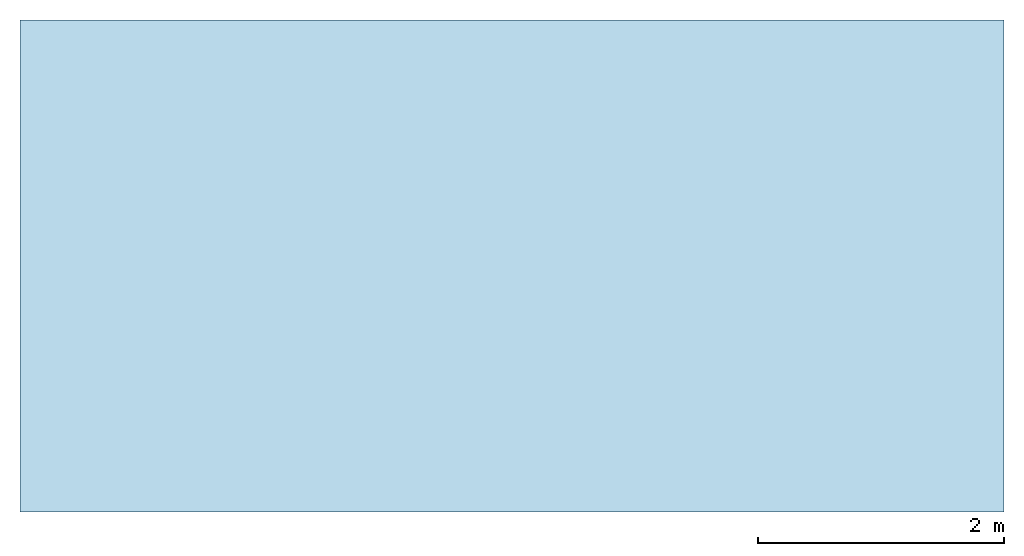
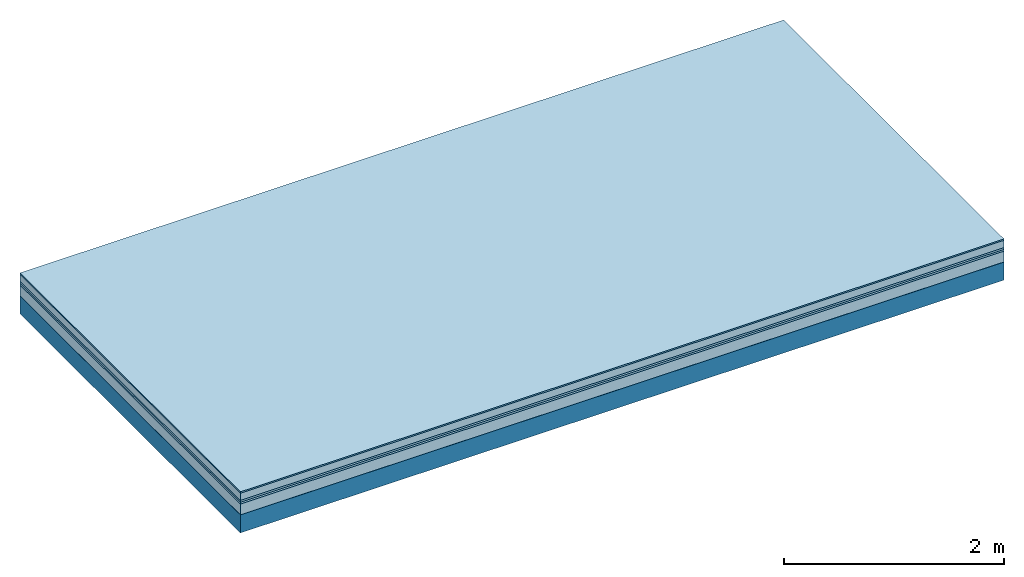
# One storey: 6 plates, 1 member, 1 element without a shape of its own.
"""IFC4 building model written with IfcOpenShell, lengths in metres."""

import ifcopenshell
import ifcopenshell.guid

model = None  # the IFC model being written
_history = None  # IfcOwnerHistory: only IFC2X3 demands one
_inside = {}  # id of a spatial element -> (the spatial element, [elements in it])
_under = {}  # id of a project, library or spatial element -> (it, [spatial elements below it])
_declared = {}  # id of a project -> (the project, [libraries it declares])
_typed = {}  # id of a type object -> (the type object, [elements of that type])
_made_of = {}  # id of a material, layer set ... -> (it, [elements and type objects made of it])


def new_model(schema):
    """Start an empty IFC model of exactly this schema.

    Asked for "IFC4X3", IfcOpenShell would pick the latest addendum, in which some entities
    have other attributes; the version numbers below select the first issue.
    IFC2X3 requires an IfcOwnerHistory on every rooted entity: one is made here for all.
    """
    global model, _history
    if schema == "IFC4X3":
        model = ifcopenshell.file(schema_version=(4, 3, 0, 0))
    else:
        model = ifcopenshell.file(schema=schema)
    _inside.clear()
    _under.clear()
    _declared.clear()
    _typed.clear()
    _made_of.clear()
    _history = None
    if model.schema == "IFC2X3":
        org = make("IfcOrganization", Name="unknown")
        user = make(
            "IfcPersonAndOrganization",
            ThePerson=make("IfcPerson", FamilyName="unknown"),
            TheOrganization=org,
        )
        app = make(
            "IfcApplication",
            ApplicationDeveloper=org,
            Version="unknown",
            ApplicationFullName="unknown",
            ApplicationIdentifier="unknown",
        )
        _history = make(
            "IfcOwnerHistory",
            OwningUser=user,
            OwningApplication=app,
            ChangeAction="ADDED",
            CreationDate=0,
        )
    return model


def make(cls, **values):
    """One entity of the class cls with the attributes given. An attribute that is None is left unset."""
    return model.create_entity(
        cls, **{name: value for name, value in values.items() if value is not None}
    )


def rooted(cls, **values):
    """An entity with a GlobalId (a new one), such as an element, a storey or a relation."""
    return make(cls, GlobalId=ifcopenshell.guid.new(), OwnerHistory=_history, **values)


def si_unit(unit_type, name, prefix=None):
    """IfcSIUnit, for example si_unit("LENGTHUNIT", "METRE", prefix="MILLI")."""
    return make("IfcSIUnit", UnitType=unit_type, Prefix=prefix, Name=name)


def derived_unit(unit_type, elements):
    """IfcDerivedUnit: a product of units, each with its exponent."""
    return make(
        "IfcDerivedUnit",
        Elements=[
            make("IfcDerivedUnitElement", Unit=unit, Exponent=power)
            for unit, power in elements
        ],
        UnitType=unit_type,
    )


def assignment(units):
    """IfcUnitAssignment: the units of a project."""
    return None if units is None else make("IfcUnitAssignment", Units=units)


def point(xyz):
    """IfcCartesianPoint."""
    return None if xyz is None else make("IfcCartesianPoint", Coordinates=xyz)


def direction(xyz):
    """IfcDirection."""
    return None if xyz is None else make("IfcDirection", DirectionRatios=xyz)


def frame(location, z_axis=None, x_axis=None):
    """IfcAxis2Placement3D, a coordinate frame: its origin and axes. An axis left out is left unset."""
    return make(
        "IfcAxis2Placement3D",
        Location=point(location),
        Axis=direction(z_axis),
        RefDirection=direction(x_axis),
    )


def frame_2d(location, x_axis=None):
    """IfcAxis2Placement2D, a coordinate frame in the plane: its origin and x axis."""
    return make(
        "IfcAxis2Placement2D", Location=point(location), RefDirection=direction(x_axis)
    )


def origin():
    """The frame at (0, 0, 0) with its axes left unset."""
    return frame((0.0, 0.0, 0.0))


def origin_with_axes():
    """The frame at (0, 0, 0) with the z axis (0, 0, 1) and the x axis (1, 0, 0) written out."""
    return frame((0.0, 0.0, 0.0), z_axis=(0.0, 0.0, 1.0), x_axis=(1.0, 0.0, 0.0))


def place(relative_to, where):
    """IfcLocalPlacement: puts the frame where relative to a parent placement (None: the world)."""
    return make(
        "IfcLocalPlacement", PlacementRelTo=relative_to, RelativePlacement=where
    )


def context(
    kind, dimensions, precision=None, world=None, true_north=None, identifier=None
):
    """IfcGeometricRepresentationContext, for example the 3D "Model" context."""
    return make(
        "IfcGeometricRepresentationContext",
        ContextIdentifier=identifier,
        ContextType=kind,
        CoordinateSpaceDimension=dimensions,
        Precision=precision,
        WorldCoordinateSystem=world,
        TrueNorth=true_north,
    )


def project(units=None, contexts=None):
    """IfcProject with its units and contexts."""
    return rooted(
        "IfcProject",
        Name="project",
        RepresentationContexts=contexts,
        UnitsInContext=assignment(units),
    )


def spatial(cls, under=None, at=None, **own):
    """A site, building, storey or space (cls), placed at a placement, below another one or the project."""
    s = rooted(cls, ObjectPlacement=at, **own)
    if under is not None:
        _under.setdefault(under.id(), (under, []))[1].append(s)
    return s


def profile(cls, at=None, kind="AREA", **sizes):
    """A parametric profile (cls). Its sizes go by their IFC names, for example OverallWidth=200.0."""
    return make(cls, ProfileType=kind, Position=at, **sizes)


def rectangle(**sizes):
    """IfcRectangleProfileDef."""
    return profile("IfcRectangleProfileDef", **sizes)


def extrude(swept, where, along, depth):
    """IfcExtrudedAreaSolid: the profile swept, set in the frame where, extruded along a direction by depth."""
    return make(
        "IfcExtrudedAreaSolid",
        SweptArea=swept,
        Position=where,
        ExtrudedDirection=direction(along),
        Depth=depth,
    )


def shape(context_of_items, identifier, shape_type, items):
    """IfcShapeRepresentation: the items that make up one representation, for example the "Body"."""
    return make(
        "IfcShapeRepresentation",
        ContextOfItems=context_of_items,
        RepresentationIdentifier=identifier,
        RepresentationType=shape_type,
        Items=items,
    )


def material(Name=None, Category=None):
    """IfcMaterial."""
    return make("IfcMaterial", Name=Name, Category=Category)


def layer(
    of_material, thickness, ventilated=None, Name=None, Category=None, Priority=None
):
    """IfcMaterialLayer: one layer of a wall or slab, of a material (None: an air gap)."""
    return make(
        "IfcMaterialLayer",
        Material=of_material,
        LayerThickness=thickness,
        IsVentilated=ventilated,
        Name=Name,
        Category=Category,
        Priority=Priority,
    )


def layer_set(layers, Name=None):
    """IfcMaterialLayerSet."""
    return make("IfcMaterialLayerSet", MaterialLayers=layers, LayerSetName=Name)


def made_of(thing, what):
    """Note that an element or type object is made of a material, layer set ...; save() writes the relation."""
    if what is not None:
        _made_of.setdefault(what.id(), (what, []))[1].append(thing)
    return thing


def type_object(cls, material=None, **own):
    """A type object (cls), such as IfcWallType, which elements share."""
    return made_of(rooted(cls, **own), material)


def element(
    cls,
    number,
    at=None,
    inside=None,
    cuts=None,
    type_object=None,
    material=None,
    context=None,
    identifier="Body",
    shape_type=None,
    held_by="IfcProductDefinitionShape",
    body=None,
    shapes=None,
    **own,
):
    """One element of the class cls, such as IfcWall. Its Tag is "e" and its number.

    at: its placement. inside: the storey or other place that contains it. cuts: it is an
    opening in that element (IfcRelVoidsElement). A single representation is given by context,
    identifier, shape_type and body (its items); several are given by shapes. held_by: the class
    of the entity that holds the representations. save() writes the other relations.
    """
    e = rooted(cls, Tag="e%d" % number, ObjectPlacement=at, **own)
    if body is not None:
        shapes = [shape(context, identifier, shape_type, body)]
    if shapes is not None:
        e.Representation = make(held_by, Representations=shapes)
    if inside is not None:
        _inside.setdefault(inside.id(), (inside, []))[1].append(e)
    if cuts is not None:
        rooted(
            "IfcRelVoidsElement", RelatingBuildingElement=cuts, RelatedOpeningElement=e
        )
    if type_object is not None:
        _typed.setdefault(type_object.id(), (type_object, []))[1].append(e)
    return made_of(e, material)


def aggregate(whole, parts):
    """IfcRelAggregates: a whole, such as a stair, and the parts it consists of."""
    return rooted("IfcRelAggregates", RelatingObject=whole, RelatedObjects=parts)


def save(model, path):
    """Write the relations noted so far, then the file.

    IfcRelAggregates (storeys below a building ...), IfcRelContainedInSpatialStructure (elements
    in a storey), IfcRelDefinesByType, IfcRelAssociatesMaterial and IfcRelDeclares: one each for
    every whole, place, type object, material and project.
    """
    for whole, parts in _under.values():
        aggregate(whole, parts)
    for where, things in _inside.values():
        rooted(
            "IfcRelContainedInSpatialStructure",
            RelatedElements=things,
            RelatingStructure=where,
        )
    for kind, things in _typed.values():
        rooted("IfcRelDefinesByType", RelatedObjects=things, RelatingType=kind)
    for what, things in _made_of.values():
        rooted("IfcRelAssociatesMaterial", RelatedObjects=things, RelatingMaterial=what)
    for by, libraries in _declared.values():
        rooted("IfcRelDeclares", RelatingContext=by, RelatedDefinitions=libraries)
    model.write(path)


model = new_model("IFC4")

# Units and contexts
plan_context = context("Plan", 3, precision=1e-05, world=origin(), true_north=direction((0.0, 1.0)))
model_context = context("Model", 3, precision=1e-05, world=origin(), true_north=direction((0.0, 1.0)))
ifc_project = project(units=[si_unit("LENGTHUNIT", "METRE"), derived_unit("SOUNDPRESSUREUNIT", [(si_unit("PRESSUREUNIT", "PASCAL", prefix="MICRO"), 0)]), si_unit("ENERGYUNIT", "JOULE", prefix="MEGA"), si_unit("MASSUNIT", "GRAM", prefix="KILO"), derived_unit("THERMALTRANSMITTANCEUNIT", [(si_unit("POWERUNIT", "WATT"), 1), (si_unit("AREAUNIT", "SQUARE_METRE"), -1), (si_unit("THERMODYNAMICTEMPERATUREUNIT", "KELVIN"), -1)]), derived_unit("AREADENSITYUNIT", [(si_unit("MASSUNIT", "GRAM", prefix="KILO"), 1), (si_unit("AREAUNIT", "SQUARE_METRE"), -1)]), derived_unit("USERDEFINED", [(si_unit("ENERGYUNIT", "JOULE", prefix="MEGA"), 1), (si_unit("AREAUNIT", "SQUARE_METRE"), -1)])], contexts=[plan_context, model_context])

# Site, building, storey
site = spatial("IfcSite", under=ifc_project)
building_placement = place(None, origin())
building = spatial("IfcBuilding", under=site, at=building_placement)
storey_placement = place(building_placement, origin())
storey = spatial("IfcBuildingStorey", under=building, at=storey_placement)

# Slab, member, plates
ifc_material_1 = material(Category="11.013")
ifc_layer_1 = layer(ifc_material_1, 0.015, Name="Flooring")
ifc_material_2 = material(Name="Cement screed", Category="04.006")
ifc_layer_2 = layer(ifc_material_2, 0.08, Name="On-material")
ifc_material_3 = material(Name="Wood fiber generic product", Category="10.009")
ifc_layer_3 = layer(ifc_material_3, 0.02, Name="Impact sound insulation")
ifc_material_4 = material()
ifc_layer_4 = layer(ifc_material_4, 0.02, Name="Additional insulation")
ifc_material_5 = material(Category="03.011")
ifc_layer_5 = layer(ifc_material_5, 0.12, Name="on Supporting structure")
ifc_material_6 = material(Name="protection", Category="09.007")
ifc_layer_6 = layer(ifc_material_6, 0.0005, Name="Sub-floor")
ifc_material_7 = material(Name="no composite action")
ifc_layer_7 = layer(ifc_material_7, 0.0, Name="Bond")
ifc_layer_8 = layer(None, 0.2, Name="Supporting structure")
ifc_layer_set = layer_set([ifc_layer_1, ifc_layer_2, ifc_layer_3, ifc_layer_4, ifc_layer_5, ifc_layer_6, ifc_layer_7, ifc_layer_8])
slab_type = type_object("IfcSlabType", Name="A2082", PredefinedType="NOTDEFINED", material=ifc_layer_set)
slab_placement = place(None, frame((0.0, 0.0, 0.0), z_axis=(0.0, 0.0, -1.0), x_axis=(1.0, 0.0, 0.0)))
slab = element("IfcSlab", 1, at=slab_placement, inside=storey, type_object=slab_type, material=ifc_layer_set, Name="Slab #1")
ifc_material_8 = material(Name="Solid timber panel")
member_placement = place(slab_placement, origin())
member = element("IfcMember", 2, at=member_placement, material=ifc_material_8, Name="Supporting structure", context=plan_context, shape_type="SweptSolid", body=[
    extrude(rectangle(XDim=1.0, YDim=0.2, at=frame_2d((0.5, 0.1), x_axis=(1.0, 0.0))), frame((0.0, 4.0, 0.2555), z_axis=(0.0, -1.0, 0.0), x_axis=(1.0, 0.0, 0.0)), (0.0, 0.0, 1.0), 4.0),
    extrude(rectangle(XDim=1.0, YDim=0.2, at=frame_2d((0.5, 0.1), x_axis=(1.0, 0.0))), frame((1.0, 4.0, 0.2555), z_axis=(0.0, -1.0, 0.0), x_axis=(1.0, 0.0, 0.0)), (0.0, 0.0, 1.0), 4.0),
    extrude(rectangle(XDim=1.0, YDim=0.2, at=frame_2d((0.5, 0.1), x_axis=(1.0, 0.0))), frame((2.0, 4.0, 0.2555), z_axis=(0.0, -1.0, 0.0), x_axis=(1.0, 0.0, 0.0)), (0.0, 0.0, 1.0), 4.0),
    extrude(rectangle(XDim=1.0, YDim=0.2, at=frame_2d((0.5, 0.1), x_axis=(1.0, 0.0))), frame((3.0, 4.0, 0.2555), z_axis=(0.0, -1.0, 0.0), x_axis=(1.0, 0.0, 0.0)), (0.0, 0.0, 1.0), 4.0),
    extrude(rectangle(XDim=1.0, YDim=0.2, at=frame_2d((0.5, 0.1), x_axis=(1.0, 0.0))), frame((4.0, 4.0, 0.2555), z_axis=(0.0, -1.0, 0.0), x_axis=(1.0, 0.0, 0.0)), (0.0, 0.0, 1.0), 4.0),
    extrude(rectangle(XDim=1.0, YDim=0.2, at=frame_2d((0.5, 0.1), x_axis=(1.0, 0.0))), frame((5.0, 4.0, 0.2555), z_axis=(0.0, -1.0, 0.0), x_axis=(1.0, 0.0, 0.0)), (0.0, 0.0, 1.0), 4.0),
    extrude(rectangle(XDim=1.0, YDim=0.2, at=frame_2d((0.5, 0.1), x_axis=(1.0, 0.0))), frame((6.0, 4.0, 0.2555), z_axis=(0.0, -1.0, 0.0), x_axis=(1.0, 0.0, 0.0)), (0.0, 0.0, 1.0), 4.0),
    extrude(rectangle(XDim=1.0, YDim=0.2, at=frame_2d((0.5, 0.1), x_axis=(1.0, 0.0))), frame((7.0, 4.0, 0.2555), z_axis=(0.0, -1.0, 0.0), x_axis=(1.0, 0.0, 0.0)), (0.0, 0.0, 1.0), 4.0),
])
plate_1_placement = place(slab_placement, origin())
plate_1 = element("IfcPlate", 3, at=plate_1_placement, material=ifc_material_1, Name="Flooring", context=plan_context, shape_type="SweptSolid", body=[
    extrude(rectangle(XDim=8.0, YDim=4.0, at=frame_2d((4.0, 2.0), x_axis=(1.0, 0.0))), origin_with_axes(), (0.0, 0.0, 1.0), 0.015),
])
plate_2_placement = place(slab_placement, origin())
plate_2 = element("IfcPlate", 4, at=plate_2_placement, material=ifc_material_2, Name="On-material", context=plan_context, shape_type="SweptSolid", body=[
    extrude(rectangle(XDim=8.0, YDim=4.0, at=frame_2d((4.0, 2.0), x_axis=(1.0, 0.0))), frame((0.0, 0.0, 0.015), z_axis=(0.0, 0.0, 1.0), x_axis=(1.0, 0.0, 0.0)), (0.0, 0.0, 1.0), 0.08),
])
plate_3_placement = place(slab_placement, origin())
plate_3 = element("IfcPlate", 5, at=plate_3_placement, material=ifc_material_3, Name="Impact sound insulation", context=plan_context, shape_type="SweptSolid", body=[
    extrude(rectangle(XDim=8.0, YDim=4.0, at=frame_2d((4.0, 2.0), x_axis=(1.0, 0.0))), frame((0.0, 0.0, 0.095), z_axis=(0.0, 0.0, 1.0), x_axis=(1.0, 0.0, 0.0)), (0.0, 0.0, 1.0), 0.02),
])
plate_4_placement = place(slab_placement, origin())
plate_4 = element("IfcPlate", 6, at=plate_4_placement, material=ifc_material_4, Name="Additional insulation", context=plan_context, shape_type="SweptSolid", body=[
    extrude(rectangle(XDim=8.0, YDim=4.0, at=frame_2d((4.0, 2.0), x_axis=(1.0, 0.0))), frame((0.0, 0.0, 0.115), z_axis=(0.0, 0.0, 1.0), x_axis=(1.0, 0.0, 0.0)), (0.0, 0.0, 1.0), 0.02),
])
plate_5_placement = place(slab_placement, origin())
plate_5 = element("IfcPlate", 7, at=plate_5_placement, material=ifc_material_5, Name="on Supporting structure", context=plan_context, shape_type="SweptSolid", body=[
    extrude(rectangle(XDim=8.0, YDim=4.0, at=frame_2d((4.0, 2.0), x_axis=(1.0, 0.0))), frame((0.0, 0.0, 0.135), z_axis=(0.0, 0.0, 1.0), x_axis=(1.0, 0.0, 0.0)), (0.0, 0.0, 1.0), 0.12),
])
plate_6_placement = place(slab_placement, origin())
plate_6 = element("IfcPlate", 8, at=plate_6_placement, material=ifc_material_6, Name="Sub-floor", context=plan_context, shape_type="SweptSolid", body=[
    extrude(rectangle(XDim=8.0, YDim=4.0, at=frame_2d((4.0, 2.0), x_axis=(1.0, 0.0))), frame((0.0, 0.0, 0.255), z_axis=(0.0, 0.0, 1.0), x_axis=(1.0, 0.0, 0.0)), (0.0, 0.0, 1.0), 0.0005),
])
aggregate(slab, [plate_1, plate_2, plate_3, plate_4, plate_5, plate_6, member])

save(model, "model.ifc")
